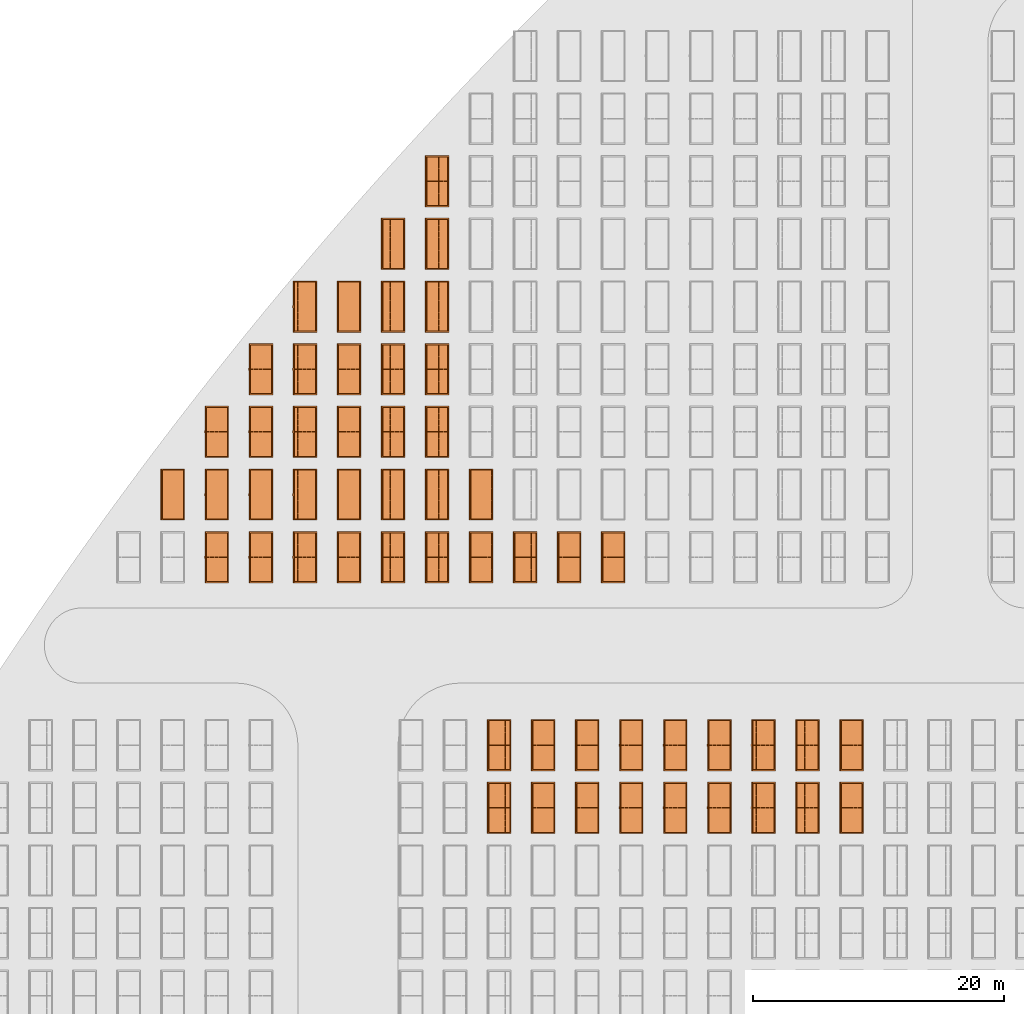
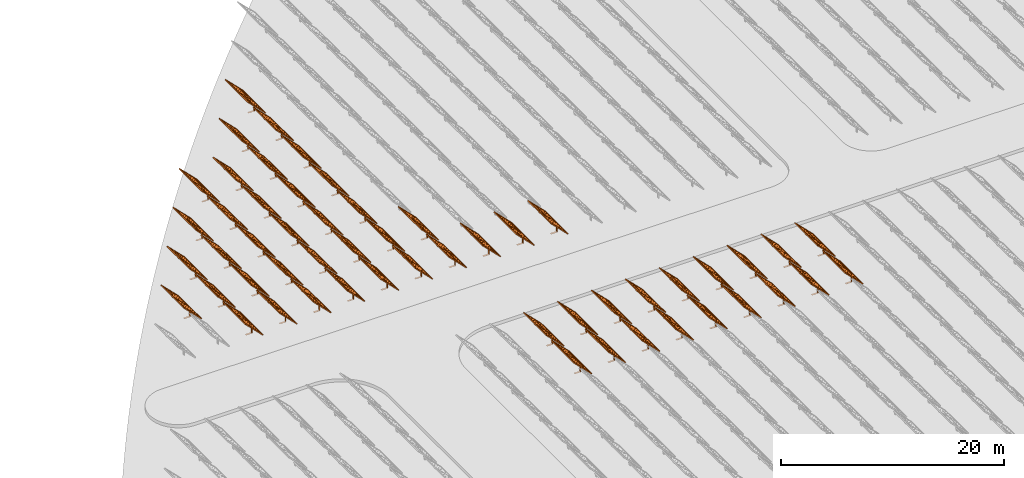
# One storey, part 33 of 39: 54 proxies.
"""IFC2X3 building model written with IfcOpenShell, lengths in millimetres."""

from ifc_helpers import new_model, entity, si_unit, converted_unit, derived_unit, direction, frame, frame_2d, origin, origin_2d_with_axis, place, context, subcontext, project, spatial, polyline, rectangle, outline, extrude, source, transform, mapped, material, material_list, element, save


model = new_model("IFC2X3")

# Units and contexts
model_context = context("Model", 3, precision=1e-06, world=origin(), true_north=direction((2.0, 6.12303176911189e-17, 1.0)))
context_of_model = context(None, 3, precision=1e-06, world=origin(), true_north=direction((2.0, 6.12303176911189e-17, 1.0)))
body_context = subcontext(model_context, "Body", "Model", "MODEL_VIEW")
ifc_project = project(units=[si_unit("LENGTHUNIT", "METRE", prefix="MILLI"), si_unit("AREAUNIT", "SQUARE_METRE", prefix="MILLI"), si_unit("VOLUMEUNIT", "CUBIC_METRE", prefix="MILLI"), converted_unit("PLANEANGLEUNIT", "DEGREE", entity("IfcRatioMeasure", 0.0174532925199433), si_unit("PLANEANGLEUNIT", "RADIAN"), dimensions=[0, 0, 0, 0, 0, 0, 0]), si_unit("MASSUNIT", "GRAM", prefix="KILO"), si_unit("TIMEUNIT", "SECOND"), si_unit("THERMODYNAMICTEMPERATUREUNIT", "KELVIN"), derived_unit("THERMALTRANSMITTANCEUNIT", [(si_unit("MASSUNIT", "GRAM", prefix="KILO"), 1), (si_unit("THERMODYNAMICTEMPERATUREUNIT", "KELVIN"), -1), (si_unit("TIMEUNIT", "SECOND"), -3)]), derived_unit("VOLUMETRICFLOWRATEUNIT", [(si_unit("LENGTHUNIT", "METRE"), 3), (si_unit("TIMEUNIT", "SECOND"), -1)])], contexts=[model_context, context_of_model])

# Site, building, storey
site_placement = place(None, origin())
site = spatial("IfcSite", under=ifc_project, at=site_placement, CompositionType="ELEMENT")
building_placement = place(site_placement, origin())
building = spatial("IfcBuilding", under=site, at=building_placement, CompositionType="ELEMENT")
storey_placement = place(building_placement, frame((0.0, 0.0, 4000.0)))
storey = spatial("IfcBuildingStorey", under=building, at=storey_placement, Name="Level 2", CompositionType="ELEMENT", Elevation=4000.0)

# Proxies
ifc_material_1 = material(Name="Stand-Steel")
ifc_material_2 = material(Name="Aluminium")
ifc_material_3 = material(Name="Glass")
ifc_material_list_1 = material_list([ifc_material_1, ifc_material_2, ifc_material_3])
shared_shape = source(origin(), body_context, "Body", "SweptSolid", [
    extrude(outline(polyline([(-629.526235435404, -220.0), (329.763117717702, -220.0), (329.763117717703, 410.0), (299.763117717703, 410.0), (299.763117717702, -190.0), (-629.526235435404, -190.0), (-629.526235435404, -220.0)])), frame((-190.00003127179, -100.0, 299.763117717707), z_axis=(0.0, 1.0, 0.0), x_axis=(0.0, 0.0, -1.0)), (0.0, 0.0, 1.0), 200.0),
    extrude(rectangle(XDim=20.0000000000001, YDim=200.0, at=frame_2d((0.0, -7.105427357601e-14), x_axis=(0.0, 1.0))), frame((-7.07109908365613, 0.0, 922.21828534124), z_axis=(-0.70710678118654, 0.0, 0.707106781186555), x_axis=(0.0, 1.0, 0.0)), (0.0, 0.0, 1.0), 2600.0),
    extrude(rectangle(XDim=24.9999999999997, YDim=24.9999999999999, at=frame_2d((2.87769807982841e-13, -9.50350909079134e-14), x_axis=(1.0, 0.0))), frame((-1449.56292018118, -1950.0, 2449.57494522722), z_axis=(0.0, 1.0, 0.0), x_axis=(-0.707106781186548, 0.0, -0.707106781186548)), (0.0, 0.0, 1.0), 3900.0),
    extrude(rectangle(XDim=24.9999999999999, YDim=25.0000000000001, at=origin_2d_with_axis()), frame((-1096.0095295879, -1950.0, 2096.02155463395), z_axis=(0.0, 1.0, 0.0), x_axis=(-0.707106781186542, 0.0, -0.707106781186553)), (0.0, 0.0, 1.0), 3900.0),
    extrude(rectangle(XDim=24.9999999999999, YDim=25.0000000000001, at=origin_2d_with_axis()), frame((-742.456138994631, -1950.0, 1742.46816404067), z_axis=(0.0, 1.0, 0.0), x_axis=(-0.707106781186542, 0.0, -0.707106781186553)), (0.0, 0.0, 1.0), 3900.0),
    extrude(rectangle(XDim=25.0, YDim=24.9999999999997, at=frame_2d((-7.19424519957101e-14, 1.19904086659517e-13), x_axis=(1.0, 0.0))), frame((-388.902748401358, -1950.0, 1388.9147734474), z_axis=(0.0, 1.0, 0.0), x_axis=(-0.707106781186545, 0.0, -0.70710678118655)), (0.0, 0.0, 1.0), 3900.0),
    extrude(rectangle(XDim=25.0000000000002, YDim=25.0, at=frame_2d((1.35891298214119e-13, 6.21724893790088e-15), x_axis=(0.0, 1.0))), frame((-35.3553703311048, 1500.0, 1035.35537033109), z_axis=(-0.707106781186544, 0.0, 0.707106781186551), x_axis=(0.0, 1.0, 0.0)), (0.0, 0.0, 1.0), 2440.0),
    extrude(rectangle(XDim=25.0000000000002, YDim=25.0, at=frame_2d((0.0, 1.77635683940025e-15), x_axis=(0.0, 1.0))), frame((-35.3553703311059, 1000.0, 1035.35537033109), z_axis=(-0.707106781186546, 0.0, 0.707106781186549), x_axis=(0.0, 1.0, 0.0)), (0.0, 0.0, 1.0), 2440.0),
    extrude(rectangle(XDim=25.0000000000002, YDim=25.0, at=frame_2d((0.0, 8.43769498715119e-14), x_axis=(0.0, 1.0))), frame((-26.5165355662756, 0.0, 1044.19420509593), z_axis=(-0.707106781186546, 0.0, 0.707106781186549), x_axis=(0.0, -1.0, 0.0)), (0.0, 0.0, 1.0), 2440.0),
    extrude(rectangle(XDim=25.0000000000002, YDim=25.0, at=frame_2d((0.0, 8.88178419700125e-16), x_axis=(0.0, 1.0))), frame((-35.3553703311065, 500.0, 1035.35537033109), z_axis=(-0.707106781186546, 0.0, 0.707106781186549), x_axis=(0.0, 1.0, 0.0)), (0.0, 0.0, 1.0), 2440.0),
    extrude(rectangle(XDim=25.0000000000002, YDim=25.0, at=frame_2d((0.0, 8.88178419700125e-16), x_axis=(0.0, 1.0))), frame((-35.3553703311086, -500.0, 1035.35537033109), z_axis=(-0.707106781186546, 0.0, 0.707106781186549), x_axis=(0.0, 1.0, 0.0)), (0.0, 0.0, 1.0), 2440.0),
    extrude(rectangle(XDim=25.0000000000002, YDim=25.0, at=frame_2d((0.0, 8.88178419700125e-16), x_axis=(0.0, 1.0))), frame((-35.3553703311095, -1000.0, 1035.35537033109), z_axis=(-0.707106781186546, 0.0, 0.707106781186549), x_axis=(0.0, 1.0, 0.0)), (0.0, 0.0, 1.0), 2440.0),
    extrude(rectangle(XDim=25.0000000000002, YDim=25.0, at=frame_2d((1.35891298214119e-13, 1.77635683940025e-15), x_axis=(0.0, 1.0))), frame((-35.3553703311107, -1500.0, 1035.35537033109), z_axis=(-0.707106781186546, 0.0, 0.707106781186549), x_axis=(0.0, 1.0, 0.0)), (0.0, 0.0, 1.0), 2440.0),
    extrude(rectangle(XDim=2400.0, YDim=11.9999999999994, at=frame_2d((-1.13686837721616e-13, 2.02948768901479e-13), x_axis=(1.0, 0.0))), frame((-883.883507754966, -1950.0, 1883.88350775495), z_axis=(0.0, 1.0, 0.0), x_axis=(0.707106781186546, 0.0, -0.707106781186549)), (0.0, 0.0, 1.0), 3900.0),
    extrude(outline(polyline([(-2050.0, -1300.0), (2050.0, -1300.0), (2050.0, 1300.0), (-2050.0, 1300.0), (-2050.0, -1300.0)]), holes=[polyline([(1950.0, -1200.0), (-1950.0, -1200.0), (-1950.0, 1200.0), (1950.0, 1200.0), (1950.0, -1200.0)])]), frame((-919.238846814293, 0.0, 1848.52816869563), z_axis=(0.707106781186554, 0.0, 0.707106781186541), x_axis=(0.0, 1.0, 0.0)), (0.0, 0.0, 1.0), 99.9999999999898),
])
proxy_1_placement = place(storey_placement, frame((-140870.317940101, 625144.680552408, 30.0)))
element("IfcBuildingElementProxy", 1, at=proxy_1_placement, inside=storey, material=ifc_material_list_1, Name="Solar Panel_4000X2500:Solar Panel_4000X2500", ObjectType="Solar Panel_4000X2500", CompositionType="ELEMENT", context=body_context, shape_type="MappedRepresentation", body=[
    mapped(shared_shape, transform((0.0, 0.0, 0.0), scale=1.0)),
])
ifc_material_list_2 = material_list([ifc_material_1, ifc_material_2, ifc_material_3])
proxy_2_placement = place(storey_placement, frame((-137355.307568371, 625144.680552408, 30.0)))
element("IfcBuildingElementProxy", 2, at=proxy_2_placement, inside=storey, material=ifc_material_list_2, Name="Solar Panel_4000X2500:Solar Panel_4000X2500", ObjectType="Solar Panel_4000X2500", CompositionType="ELEMENT", context=body_context, shape_type="MappedRepresentation", body=[
    mapped(shared_shape, transform((0.0, 0.0, 0.0), scale=1.0)),
])
ifc_material_list_3 = material_list([ifc_material_1, ifc_material_2, ifc_material_3])
proxy_3_placement = place(storey_placement, frame((-133840.297196641, 625144.680552408, 30.0)))
element("IfcBuildingElementProxy", 3, at=proxy_3_placement, inside=storey, material=ifc_material_list_3, Name="Solar Panel_4000X2500:Solar Panel_4000X2500", ObjectType="Solar Panel_4000X2500", CompositionType="ELEMENT", context=body_context, shape_type="MappedRepresentation", body=[
    mapped(shared_shape, transform((0.0, 0.0, 0.0), scale=1.0)),
])
ifc_material_list_4 = material_list([ifc_material_1, ifc_material_2, ifc_material_3])
proxy_4_placement = place(storey_placement, frame((-130325.286824911, 625144.680552408, 30.0)))
element("IfcBuildingElementProxy", 4, at=proxy_4_placement, inside=storey, material=ifc_material_list_4, Name="Solar Panel_4000X2500:Solar Panel_4000X2500", ObjectType="Solar Panel_4000X2500", CompositionType="ELEMENT", context=body_context, shape_type="MappedRepresentation", body=[
    mapped(shared_shape, transform((0.0, 0.0, 0.0), scale=1.0)),
])
ifc_material_list_5 = material_list([ifc_material_1, ifc_material_2, ifc_material_3])
proxy_5_placement = place(storey_placement, frame((-140870.317940101, 630144.680552408, 30.0)))
element("IfcBuildingElementProxy", 5, at=proxy_5_placement, inside=storey, material=ifc_material_list_5, Name="Solar Panel_4000X2500:Solar Panel_4000X2500", ObjectType="Solar Panel_4000X2500", CompositionType="ELEMENT", context=body_context, shape_type="MappedRepresentation", body=[
    mapped(shared_shape, transform((0.0, 0.0, 0.0), scale=1.0)),
])
ifc_material_list_6 = material_list([ifc_material_1, ifc_material_2, ifc_material_3])
proxy_6_placement = place(storey_placement, frame((-137355.307568371, 630144.680552408, 30.0)))
element("IfcBuildingElementProxy", 6, at=proxy_6_placement, inside=storey, material=ifc_material_list_6, Name="Solar Panel_4000X2500:Solar Panel_4000X2500", ObjectType="Solar Panel_4000X2500", CompositionType="ELEMENT", context=body_context, shape_type="MappedRepresentation", body=[
    mapped(shared_shape, transform((0.0, 0.0, 0.0), scale=1.0)),
])
ifc_material_list_7 = material_list([ifc_material_1, ifc_material_2, ifc_material_3])
proxy_7_placement = place(storey_placement, frame((-133840.297196641, 630144.680552408, 30.0)))
element("IfcBuildingElementProxy", 7, at=proxy_7_placement, inside=storey, material=ifc_material_list_7, Name="Solar Panel_4000X2500:Solar Panel_4000X2500", ObjectType="Solar Panel_4000X2500", CompositionType="ELEMENT", context=body_context, shape_type="MappedRepresentation", body=[
    mapped(shared_shape, transform((0.0, 0.0, 0.0), scale=1.0)),
])
ifc_material_list_8 = material_list([ifc_material_1, ifc_material_2, ifc_material_3])
proxy_8_placement = place(storey_placement, frame((-130325.286824911, 630144.680552408, 30.0)))
element("IfcBuildingElementProxy", 8, at=proxy_8_placement, inside=storey, material=ifc_material_list_8, Name="Solar Panel_4000X2500:Solar Panel_4000X2500", ObjectType="Solar Panel_4000X2500", CompositionType="ELEMENT", context=body_context, shape_type="MappedRepresentation", body=[
    mapped(shared_shape, transform((0.0, 0.0, 0.0), scale=1.0)),
])
ifc_material_list_9 = material_list([ifc_material_1, ifc_material_2, ifc_material_3])
proxy_9_placement = place(storey_placement, frame((-126810.276453181, 625144.680552408, 30.0)))
element("IfcBuildingElementProxy", 9, at=proxy_9_placement, inside=storey, material=ifc_material_list_9, Name="Solar Panel_4000X2500:Solar Panel_4000X2500", ObjectType="Solar Panel_4000X2500", CompositionType="ELEMENT", context=body_context, shape_type="MappedRepresentation", body=[
    mapped(shared_shape, transform((0.0, 0.0, 0.0), scale=1.0)),
])
ifc_material_list_10 = material_list([ifc_material_1, ifc_material_2, ifc_material_3])
proxy_10_placement = place(storey_placement, frame((-126810.276453181, 630144.680552408, 30.0)))
element("IfcBuildingElementProxy", 10, at=proxy_10_placement, inside=storey, material=ifc_material_list_10, Name="Solar Panel_4000X2500:Solar Panel_4000X2500", ObjectType="Solar Panel_4000X2500", CompositionType="ELEMENT", context=body_context, shape_type="MappedRepresentation", body=[
    mapped(shared_shape, transform((0.0, 0.0, 0.0), scale=1.0)),
])
ifc_material_list_11 = material_list([ifc_material_1, ifc_material_2, ifc_material_3])
proxy_11_placement = place(storey_placement, frame((-123295.266081452, 625144.680552408, 30.0)))
element("IfcBuildingElementProxy", 11, at=proxy_11_placement, inside=storey, material=ifc_material_list_11, Name="Solar Panel_4000X2500:Solar Panel_4000X2500", ObjectType="Solar Panel_4000X2500", CompositionType="ELEMENT", context=body_context, shape_type="MappedRepresentation", body=[
    mapped(shared_shape, transform((0.0, 0.0, 0.0), scale=1.0)),
])
ifc_material_list_12 = material_list([ifc_material_1, ifc_material_2, ifc_material_3])
proxy_12_placement = place(storey_placement, frame((-123295.266081452, 630144.680552408, 30.0)))
element("IfcBuildingElementProxy", 12, at=proxy_12_placement, inside=storey, material=ifc_material_list_12, Name="Solar Panel_4000X2500:Solar Panel_4000X2500", ObjectType="Solar Panel_4000X2500", CompositionType="ELEMENT", context=body_context, shape_type="MappedRepresentation", body=[
    mapped(shared_shape, transform((0.0, 0.0, 0.0), scale=1.0)),
])
ifc_material_list_13 = material_list([ifc_material_1, ifc_material_2, ifc_material_3])
proxy_13_placement = place(storey_placement, frame((-119780.255709722, 625144.680552408, 30.0)))
element("IfcBuildingElementProxy", 13, at=proxy_13_placement, inside=storey, material=ifc_material_list_13, Name="Solar Panel_4000X2500:Solar Panel_4000X2500", ObjectType="Solar Panel_4000X2500", CompositionType="ELEMENT", context=body_context, shape_type="MappedRepresentation", body=[
    mapped(shared_shape, transform((0.0, 0.0, 0.0), scale=1.0)),
])
ifc_material_list_14 = material_list([ifc_material_1, ifc_material_2, ifc_material_3])
proxy_14_placement = place(storey_placement, frame((-119780.255709722, 630144.680552408, 30.0)))
element("IfcBuildingElementProxy", 14, at=proxy_14_placement, inside=storey, material=ifc_material_list_14, Name="Solar Panel_4000X2500:Solar Panel_4000X2500", ObjectType="Solar Panel_4000X2500", CompositionType="ELEMENT", context=body_context, shape_type="MappedRepresentation", body=[
    mapped(shared_shape, transform((0.0, 0.0, 0.0), scale=1.0)),
])
ifc_material_list_15 = material_list([ifc_material_1, ifc_material_2, ifc_material_3])
proxy_15_placement = place(storey_placement, frame((-116265.245337992, 625144.680552408, 30.0)))
element("IfcBuildingElementProxy", 15, at=proxy_15_placement, inside=storey, material=ifc_material_list_15, Name="Solar Panel_4000X2500:Solar Panel_4000X2500", ObjectType="Solar Panel_4000X2500", CompositionType="ELEMENT", context=body_context, shape_type="MappedRepresentation", body=[
    mapped(shared_shape, transform((0.0, 0.0, 0.0), scale=1.0)),
])
ifc_material_list_16 = material_list([ifc_material_1, ifc_material_2, ifc_material_3])
proxy_16_placement = place(storey_placement, frame((-116265.245337992, 630144.680552408, 30.0)))
element("IfcBuildingElementProxy", 16, at=proxy_16_placement, inside=storey, material=ifc_material_list_16, Name="Solar Panel_4000X2500:Solar Panel_4000X2500", ObjectType="Solar Panel_4000X2500", CompositionType="ELEMENT", context=body_context, shape_type="MappedRepresentation", body=[
    mapped(shared_shape, transform((0.0, 0.0, 0.0), scale=1.0)),
])
ifc_material_list_17 = material_list([ifc_material_1, ifc_material_2, ifc_material_3])
proxy_17_placement = place(storey_placement, frame((-112750.234966262, 625144.680552408, 30.0)))
element("IfcBuildingElementProxy", 17, at=proxy_17_placement, inside=storey, material=ifc_material_list_17, Name="Solar Panel_4000X2500:Solar Panel_4000X2500", ObjectType="Solar Panel_4000X2500", CompositionType="ELEMENT", context=body_context, shape_type="MappedRepresentation", body=[
    mapped(shared_shape, transform((0.0, 0.0, 0.0), scale=1.0)),
])
ifc_material_list_18 = material_list([ifc_material_1, ifc_material_2, ifc_material_3])
proxy_18_placement = place(storey_placement, frame((-112750.234966262, 630144.680552408, 30.0)))
element("IfcBuildingElementProxy", 18, at=proxy_18_placement, inside=storey, material=ifc_material_list_18, Name="Solar Panel_4000X2500:Solar Panel_4000X2500", ObjectType="Solar Panel_4000X2500", CompositionType="ELEMENT", context=body_context, shape_type="MappedRepresentation", body=[
    mapped(shared_shape, transform((0.0, 0.0, 0.0), scale=1.0)),
])
ifc_material_list_19 = material_list([ifc_material_1, ifc_material_2, ifc_material_3])
proxy_19_placement = place(storey_placement, frame((-142310.3179401, 645144.680552408, 30.0)))
element("IfcBuildingElementProxy", 19, at=proxy_19_placement, inside=storey, material=ifc_material_list_19, Name="Solar Panel_4000X2500:Solar Panel_4000X2500", ObjectType="Solar Panel_4000X2500", CompositionType="ELEMENT", context=body_context, shape_type="MappedRepresentation", body=[
    mapped(shared_shape, transform((0.0, 0.0, 0.0), scale=1.0)),
])
ifc_material_list_20 = material_list([ifc_material_1, ifc_material_2, ifc_material_3])
proxy_20_placement = place(storey_placement, frame((-138795.307568371, 645144.680552408, 30.0)))
element("IfcBuildingElementProxy", 20, at=proxy_20_placement, inside=storey, material=ifc_material_list_20, Name="Solar Panel_4000X2500:Solar Panel_4000X2500", ObjectType="Solar Panel_4000X2500", CompositionType="ELEMENT", context=body_context, shape_type="MappedRepresentation", body=[
    mapped(shared_shape, transform((0.0, 0.0, 0.0), scale=1.0)),
])
ifc_material_list_21 = material_list([ifc_material_1, ifc_material_2, ifc_material_3])
proxy_21_placement = place(storey_placement, frame((-135280.297196641, 645144.680552408, 30.0)))
element("IfcBuildingElementProxy", 21, at=proxy_21_placement, inside=storey, material=ifc_material_list_21, Name="Solar Panel_4000X2500:Solar Panel_4000X2500", ObjectType="Solar Panel_4000X2500", CompositionType="ELEMENT", context=body_context, shape_type="MappedRepresentation", body=[
    mapped(shared_shape, transform((0.0, 0.0, 0.0), scale=1.0)),
])
ifc_material_list_22 = material_list([ifc_material_1, ifc_material_2, ifc_material_3])
proxy_22_placement = place(storey_placement, frame((-131765.286824911, 645144.680552408, 30.0)))
element("IfcBuildingElementProxy", 22, at=proxy_22_placement, inside=storey, material=ifc_material_list_22, Name="Solar Panel_4000X2500:Solar Panel_4000X2500", ObjectType="Solar Panel_4000X2500", CompositionType="ELEMENT", context=body_context, shape_type="MappedRepresentation", body=[
    mapped(shared_shape, transform((0.0, 0.0, 0.0), scale=1.0)),
])
ifc_material_list_23 = material_list([ifc_material_1, ifc_material_2, ifc_material_3])
proxy_23_placement = place(storey_placement, frame((-159885.32831183, 645144.680552408, 30.0)))
element("IfcBuildingElementProxy", 23, at=proxy_23_placement, inside=storey, material=ifc_material_list_23, Name="Solar Panel_4000X2500:Solar Panel_4000X2500", ObjectType="Solar Panel_4000X2500", CompositionType="ELEMENT", context=body_context, shape_type="MappedRepresentation", body=[
    mapped(shared_shape, transform((0.0, 0.0, 0.0), scale=1.0)),
])
ifc_material_list_24 = material_list([ifc_material_1, ifc_material_2, ifc_material_3])
proxy_24_placement = place(storey_placement, frame((-163400.32831183, 645144.680552408, 30.0)))
element("IfcBuildingElementProxy", 24, at=proxy_24_placement, inside=storey, material=ifc_material_list_24, Name="Solar Panel_4000X2500:Solar Panel_4000X2500", ObjectType="Solar Panel_4000X2500", CompositionType="ELEMENT", context=body_context, shape_type="MappedRepresentation", body=[
    mapped(shared_shape, transform((0.0, 0.0, 0.0), scale=1.0)),
])
ifc_material_list_25 = material_list([ifc_material_1, ifc_material_2, ifc_material_3])
proxy_25_placement = place(storey_placement, frame((-152855.32831183, 645144.680552408, 30.0)))
element("IfcBuildingElementProxy", 25, at=proxy_25_placement, inside=storey, material=ifc_material_list_25, Name="Solar Panel_4000X2500:Solar Panel_4000X2500", ObjectType="Solar Panel_4000X2500", CompositionType="ELEMENT", context=body_context, shape_type="MappedRepresentation", body=[
    mapped(shared_shape, transform((0.0, 0.0, 0.0), scale=1.0)),
])
ifc_material_list_26 = material_list([ifc_material_1, ifc_material_2, ifc_material_3])
proxy_26_placement = place(storey_placement, frame((-156370.32831183, 645144.680552408, 30.0)))
element("IfcBuildingElementProxy", 26, at=proxy_26_placement, inside=storey, material=ifc_material_list_26, Name="Solar Panel_4000X2500:Solar Panel_4000X2500", ObjectType="Solar Panel_4000X2500", CompositionType="ELEMENT", context=body_context, shape_type="MappedRepresentation", body=[
    mapped(shared_shape, transform((0.0, 0.0, 0.0), scale=1.0)),
])
ifc_material_list_27 = material_list([ifc_material_1, ifc_material_2, ifc_material_3])
proxy_27_placement = place(storey_placement, frame((-145825.32831183, 645144.680552408, 30.0)))
element("IfcBuildingElementProxy", 27, at=proxy_27_placement, inside=storey, material=ifc_material_list_27, Name="Solar Panel_4000X2500:Solar Panel_4000X2500", ObjectType="Solar Panel_4000X2500", CompositionType="ELEMENT", context=body_context, shape_type="MappedRepresentation", body=[
    mapped(shared_shape, transform((0.0, 0.0, 0.0), scale=1.0)),
])
ifc_material_list_28 = material_list([ifc_material_1, ifc_material_2, ifc_material_3])
proxy_28_placement = place(storey_placement, frame((-149340.32831183, 645144.680552408, 30.0)))
element("IfcBuildingElementProxy", 28, at=proxy_28_placement, inside=storey, material=ifc_material_list_28, Name="Solar Panel_4000X2500:Solar Panel_4000X2500", ObjectType="Solar Panel_4000X2500", CompositionType="ELEMENT", context=body_context, shape_type="MappedRepresentation", body=[
    mapped(shared_shape, transform((0.0, 0.0, 0.0), scale=1.0)),
])
ifc_material_list_29 = material_list([ifc_material_1, ifc_material_2, ifc_material_3])
proxy_29_placement = place(storey_placement, frame((-142310.3179401, 650144.680552408, 30.0)))
element("IfcBuildingElementProxy", 29, at=proxy_29_placement, inside=storey, material=ifc_material_list_29, Name="Solar Panel_4000X2500:Solar Panel_4000X2500", ObjectType="Solar Panel_4000X2500", CompositionType="ELEMENT", context=body_context, shape_type="MappedRepresentation", body=[
    mapped(shared_shape, transform((0.0, 0.0, 0.0), scale=1.0)),
])
ifc_material_list_30 = material_list([ifc_material_1, ifc_material_2, ifc_material_3])
proxy_30_placement = place(storey_placement, frame((-159885.32831183, 650144.680552408, 30.0)))
element("IfcBuildingElementProxy", 30, at=proxy_30_placement, inside=storey, material=ifc_material_list_30, Name="Solar Panel_4000X2500:Solar Panel_4000X2500", ObjectType="Solar Panel_4000X2500", CompositionType="ELEMENT", context=body_context, shape_type="MappedRepresentation", body=[
    mapped(shared_shape, transform((0.0, 0.0, 0.0), scale=1.0)),
])
ifc_material_list_31 = material_list([ifc_material_1, ifc_material_2, ifc_material_3])
proxy_31_placement = place(storey_placement, frame((-163400.32831183, 650144.680552408, 30.0)))
element("IfcBuildingElementProxy", 31, at=proxy_31_placement, inside=storey, material=ifc_material_list_31, Name="Solar Panel_4000X2500:Solar Panel_4000X2500", ObjectType="Solar Panel_4000X2500", CompositionType="ELEMENT", context=body_context, shape_type="MappedRepresentation", body=[
    mapped(shared_shape, transform((0.0, 0.0, 0.0), scale=1.0)),
])
ifc_material_list_32 = material_list([ifc_material_1, ifc_material_2, ifc_material_3])
proxy_32_placement = place(storey_placement, frame((-166915.32831183, 650144.680552408, 30.0)))
element("IfcBuildingElementProxy", 32, at=proxy_32_placement, inside=storey, material=ifc_material_list_32, Name="Solar Panel_4000X2500:Solar Panel_4000X2500", ObjectType="Solar Panel_4000X2500", CompositionType="ELEMENT", context=body_context, shape_type="MappedRepresentation", body=[
    mapped(shared_shape, transform((0.0, 0.0, 0.0), scale=1.0)),
])
ifc_material_list_33 = material_list([ifc_material_1, ifc_material_2, ifc_material_3])
proxy_33_placement = place(storey_placement, frame((-152855.32831183, 650144.680552408, 30.0)))
element("IfcBuildingElementProxy", 33, at=proxy_33_placement, inside=storey, material=ifc_material_list_33, Name="Solar Panel_4000X2500:Solar Panel_4000X2500", ObjectType="Solar Panel_4000X2500", CompositionType="ELEMENT", context=body_context, shape_type="MappedRepresentation", body=[
    mapped(shared_shape, transform((0.0, 0.0, 0.0), scale=1.0)),
])
ifc_material_list_34 = material_list([ifc_material_1, ifc_material_2, ifc_material_3])
proxy_34_placement = place(storey_placement, frame((-156370.32831183, 650144.680552408, 30.0)))
element("IfcBuildingElementProxy", 34, at=proxy_34_placement, inside=storey, material=ifc_material_list_34, Name="Solar Panel_4000X2500:Solar Panel_4000X2500", ObjectType="Solar Panel_4000X2500", CompositionType="ELEMENT", context=body_context, shape_type="MappedRepresentation", body=[
    mapped(shared_shape, transform((0.0, 0.0, 0.0), scale=1.0)),
])
ifc_material_list_35 = material_list([ifc_material_1, ifc_material_2, ifc_material_3])
proxy_35_placement = place(storey_placement, frame((-145825.32831183, 650144.680552408, 30.0)))
element("IfcBuildingElementProxy", 35, at=proxy_35_placement, inside=storey, material=ifc_material_list_35, Name="Solar Panel_4000X2500:Solar Panel_4000X2500", ObjectType="Solar Panel_4000X2500", CompositionType="ELEMENT", context=body_context, shape_type="MappedRepresentation", body=[
    mapped(shared_shape, transform((0.0, 0.0, 0.0), scale=1.0)),
])
ifc_material_list_36 = material_list([ifc_material_1, ifc_material_2, ifc_material_3])
proxy_36_placement = place(storey_placement, frame((-149340.32831183, 650144.680552408, 30.0)))
element("IfcBuildingElementProxy", 36, at=proxy_36_placement, inside=storey, material=ifc_material_list_36, Name="Solar Panel_4000X2500:Solar Panel_4000X2500", ObjectType="Solar Panel_4000X2500", CompositionType="ELEMENT", context=body_context, shape_type="MappedRepresentation", body=[
    mapped(shared_shape, transform((0.0, 0.0, 0.0), scale=1.0)),
])
ifc_material_list_37 = material_list([ifc_material_1, ifc_material_2, ifc_material_3])
proxy_37_placement = place(storey_placement, frame((-159885.32831183, 655144.680552408, 30.0)))
element("IfcBuildingElementProxy", 37, at=proxy_37_placement, inside=storey, material=ifc_material_list_37, Name="Solar Panel_4000X2500:Solar Panel_4000X2500", ObjectType="Solar Panel_4000X2500", CompositionType="ELEMENT", context=body_context, shape_type="MappedRepresentation", body=[
    mapped(shared_shape, transform((0.0, 0.0, 0.0), scale=1.0)),
])
ifc_material_list_38 = material_list([ifc_material_1, ifc_material_2, ifc_material_3])
proxy_38_placement = place(storey_placement, frame((-163400.32831183, 655144.680552408, 30.0)))
element("IfcBuildingElementProxy", 38, at=proxy_38_placement, inside=storey, material=ifc_material_list_38, Name="Solar Panel_4000X2500:Solar Panel_4000X2500", ObjectType="Solar Panel_4000X2500", CompositionType="ELEMENT", context=body_context, shape_type="MappedRepresentation", body=[
    mapped(shared_shape, transform((0.0, 0.0, 0.0), scale=1.0)),
])
ifc_material_list_39 = material_list([ifc_material_1, ifc_material_2, ifc_material_3])
proxy_39_placement = place(storey_placement, frame((-152855.32831183, 655144.680552408, 30.0)))
element("IfcBuildingElementProxy", 39, at=proxy_39_placement, inside=storey, material=ifc_material_list_39, Name="Solar Panel_4000X2500:Solar Panel_4000X2500", ObjectType="Solar Panel_4000X2500", CompositionType="ELEMENT", context=body_context, shape_type="MappedRepresentation", body=[
    mapped(shared_shape, transform((0.0, 0.0, 0.0), scale=1.0)),
])
ifc_material_list_40 = material_list([ifc_material_1, ifc_material_2, ifc_material_3])
proxy_40_placement = place(storey_placement, frame((-156370.32831183, 655144.680552408, 30.0)))
element("IfcBuildingElementProxy", 40, at=proxy_40_placement, inside=storey, material=ifc_material_list_40, Name="Solar Panel_4000X2500:Solar Panel_4000X2500", ObjectType="Solar Panel_4000X2500", CompositionType="ELEMENT", context=body_context, shape_type="MappedRepresentation", body=[
    mapped(shared_shape, transform((0.0, 0.0, 0.0), scale=1.0)),
])
ifc_material_list_41 = material_list([ifc_material_1, ifc_material_2, ifc_material_3])
proxy_41_placement = place(storey_placement, frame((-145825.32831183, 655144.680552408, 30.0)))
element("IfcBuildingElementProxy", 41, at=proxy_41_placement, inside=storey, material=ifc_material_list_41, Name="Solar Panel_4000X2500:Solar Panel_4000X2500", ObjectType="Solar Panel_4000X2500", CompositionType="ELEMENT", context=body_context, shape_type="MappedRepresentation", body=[
    mapped(shared_shape, transform((0.0, 0.0, 0.0), scale=1.0)),
])
ifc_material_list_42 = material_list([ifc_material_1, ifc_material_2, ifc_material_3])
proxy_42_placement = place(storey_placement, frame((-149340.32831183, 655144.680552408, 30.0)))
element("IfcBuildingElementProxy", 42, at=proxy_42_placement, inside=storey, material=ifc_material_list_42, Name="Solar Panel_4000X2500:Solar Panel_4000X2500", ObjectType="Solar Panel_4000X2500", CompositionType="ELEMENT", context=body_context, shape_type="MappedRepresentation", body=[
    mapped(shared_shape, transform((0.0, 0.0, 0.0), scale=1.0)),
])
ifc_material_list_43 = material_list([ifc_material_1, ifc_material_2, ifc_material_3])
proxy_43_placement = place(storey_placement, frame((-159885.32831183, 660144.680552408, 30.0)))
element("IfcBuildingElementProxy", 43, at=proxy_43_placement, inside=storey, material=ifc_material_list_43, Name="Solar Panel_4000X2500:Solar Panel_4000X2500", ObjectType="Solar Panel_4000X2500", CompositionType="ELEMENT", context=body_context, shape_type="MappedRepresentation", body=[
    mapped(shared_shape, transform((0.0, 0.0, 0.0), scale=1.0)),
])
ifc_material_list_44 = material_list([ifc_material_1, ifc_material_2, ifc_material_3])
proxy_44_placement = place(storey_placement, frame((-152855.32831183, 660144.680552408, 30.0)))
element("IfcBuildingElementProxy", 44, at=proxy_44_placement, inside=storey, material=ifc_material_list_44, Name="Solar Panel_4000X2500:Solar Panel_4000X2500", ObjectType="Solar Panel_4000X2500", CompositionType="ELEMENT", context=body_context, shape_type="MappedRepresentation", body=[
    mapped(shared_shape, transform((0.0, 0.0, 0.0), scale=1.0)),
])
ifc_material_list_45 = material_list([ifc_material_1, ifc_material_2, ifc_material_3])
proxy_45_placement = place(storey_placement, frame((-156370.32831183, 660144.680552408, 30.0)))
element("IfcBuildingElementProxy", 45, at=proxy_45_placement, inside=storey, material=ifc_material_list_45, Name="Solar Panel_4000X2500:Solar Panel_4000X2500", ObjectType="Solar Panel_4000X2500", CompositionType="ELEMENT", context=body_context, shape_type="MappedRepresentation", body=[
    mapped(shared_shape, transform((0.0, 0.0, 0.0), scale=1.0)),
])
ifc_material_list_46 = material_list([ifc_material_1, ifc_material_2, ifc_material_3])
proxy_46_placement = place(storey_placement, frame((-145825.32831183, 660144.680552408, 30.0)))
element("IfcBuildingElementProxy", 46, at=proxy_46_placement, inside=storey, material=ifc_material_list_46, Name="Solar Panel_4000X2500:Solar Panel_4000X2500", ObjectType="Solar Panel_4000X2500", CompositionType="ELEMENT", context=body_context, shape_type="MappedRepresentation", body=[
    mapped(shared_shape, transform((0.0, 0.0, 0.0), scale=1.0)),
])
ifc_material_list_47 = material_list([ifc_material_1, ifc_material_2, ifc_material_3])
proxy_47_placement = place(storey_placement, frame((-149340.32831183, 660144.680552408, 30.0)))
element("IfcBuildingElementProxy", 47, at=proxy_47_placement, inside=storey, material=ifc_material_list_47, Name="Solar Panel_4000X2500:Solar Panel_4000X2500", ObjectType="Solar Panel_4000X2500", CompositionType="ELEMENT", context=body_context, shape_type="MappedRepresentation", body=[
    mapped(shared_shape, transform((0.0, 0.0, 0.0), scale=1.0)),
])
ifc_material_list_48 = material_list([ifc_material_1, ifc_material_2, ifc_material_3])
proxy_48_placement = place(storey_placement, frame((-152855.32831183, 665144.680552408, 30.0)))
element("IfcBuildingElementProxy", 48, at=proxy_48_placement, inside=storey, material=ifc_material_list_48, Name="Solar Panel_4000X2500:Solar Panel_4000X2500", ObjectType="Solar Panel_4000X2500", CompositionType="ELEMENT", context=body_context, shape_type="MappedRepresentation", body=[
    mapped(shared_shape, transform((0.0, 0.0, 0.0), scale=1.0)),
])
ifc_material_list_49 = material_list([ifc_material_1, ifc_material_2, ifc_material_3])
proxy_49_placement = place(storey_placement, frame((-156370.32831183, 665144.680552408, 30.0)))
element("IfcBuildingElementProxy", 49, at=proxy_49_placement, inside=storey, material=ifc_material_list_49, Name="Solar Panel_4000X2500:Solar Panel_4000X2500", ObjectType="Solar Panel_4000X2500", CompositionType="ELEMENT", context=body_context, shape_type="MappedRepresentation", body=[
    mapped(shared_shape, transform((0.0, 0.0, 0.0), scale=1.0)),
])
ifc_material_list_50 = material_list([ifc_material_1, ifc_material_2, ifc_material_3])
proxy_50_placement = place(storey_placement, frame((-145825.32831183, 665144.680552408, 30.0)))
element("IfcBuildingElementProxy", 50, at=proxy_50_placement, inside=storey, material=ifc_material_list_50, Name="Solar Panel_4000X2500:Solar Panel_4000X2500", ObjectType="Solar Panel_4000X2500", CompositionType="ELEMENT", context=body_context, shape_type="MappedRepresentation", body=[
    mapped(shared_shape, transform((0.0, 0.0, 0.0), scale=1.0)),
])
ifc_material_list_51 = material_list([ifc_material_1, ifc_material_2, ifc_material_3])
proxy_51_placement = place(storey_placement, frame((-149340.32831183, 665144.680552408, 30.0)))
element("IfcBuildingElementProxy", 51, at=proxy_51_placement, inside=storey, material=ifc_material_list_51, Name="Solar Panel_4000X2500:Solar Panel_4000X2500", ObjectType="Solar Panel_4000X2500", CompositionType="ELEMENT", context=body_context, shape_type="MappedRepresentation", body=[
    mapped(shared_shape, transform((0.0, 0.0, 0.0), scale=1.0)),
])
ifc_material_list_52 = material_list([ifc_material_1, ifc_material_2, ifc_material_3])
proxy_52_placement = place(storey_placement, frame((-145825.32831183, 670144.680552408, 30.0)))
element("IfcBuildingElementProxy", 52, at=proxy_52_placement, inside=storey, material=ifc_material_list_52, Name="Solar Panel_4000X2500:Solar Panel_4000X2500", ObjectType="Solar Panel_4000X2500", CompositionType="ELEMENT", context=body_context, shape_type="MappedRepresentation", body=[
    mapped(shared_shape, transform((0.0, 0.0, 0.0), scale=1.0)),
])
ifc_material_list_53 = material_list([ifc_material_1, ifc_material_2, ifc_material_3])
proxy_53_placement = place(storey_placement, frame((-149340.32831183, 670144.680552408, 30.0)))
element("IfcBuildingElementProxy", 53, at=proxy_53_placement, inside=storey, material=ifc_material_list_53, Name="Solar Panel_4000X2500:Solar Panel_4000X2500", ObjectType="Solar Panel_4000X2500", CompositionType="ELEMENT", context=body_context, shape_type="MappedRepresentation", body=[
    mapped(shared_shape, transform((0.0, 0.0, 0.0), scale=1.0)),
])
ifc_material_list_54 = material_list([ifc_material_1, ifc_material_2, ifc_material_3])
proxy_54_placement = place(storey_placement, frame((-145825.32831183, 675144.680552408, 30.0)))
element("IfcBuildingElementProxy", 54, at=proxy_54_placement, inside=storey, material=ifc_material_list_54, Name="Solar Panel_4000X2500:Solar Panel_4000X2500", ObjectType="Solar Panel_4000X2500", CompositionType="ELEMENT", context=body_context, shape_type="MappedRepresentation", body=[
    mapped(shared_shape, transform((0.0, 0.0, 0.0), scale=1.0)),
])

save(model, "model.ifc")
